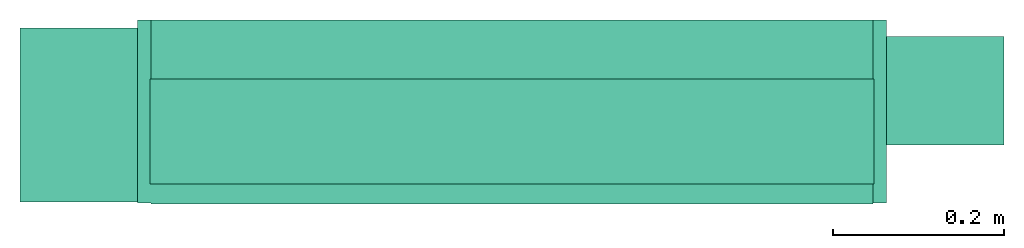
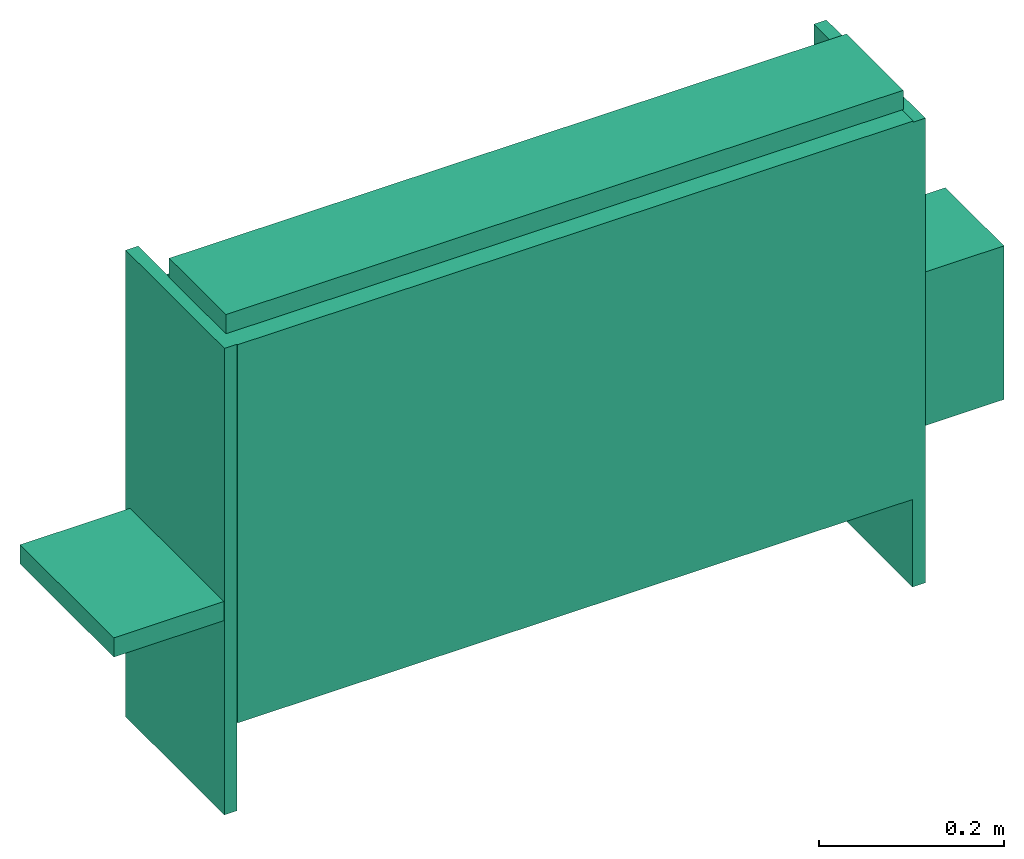
# One storey: 1 energy conversion device.
"""IFC2X3 building model written with IfcOpenShell, lengths in metres."""

from ifc_helpers import new_model, entity, si_unit, converted_unit, origin, origin_with_axes, place, context, subcontext, project, spatial, faceted_brep, type_object, element, save


model = new_model("IFC2X3")

# Units and contexts
model_context = context("Model", 3, precision=1e-05, world=origin())
body_context = subcontext(model_context, "Body", "Model", "MODEL_VIEW")
ifc_project = project(units=[si_unit("LENGTHUNIT", "METRE"), si_unit("AREAUNIT", "SQUARE_METRE"), si_unit("VOLUMEUNIT", "CUBIC_METRE"), converted_unit("PLANEANGLEUNIT", "DEGREE", entity("IfcPlaneAngleMeasure", 0.0174532925199433), si_unit("PLANEANGLEUNIT", "RADIAN"), dimensions=[0, 0, 0, 0, 0, 0, 0]), si_unit("SOLIDANGLEUNIT", "STERADIAN"), si_unit("MASSUNIT", "GRAM"), si_unit("TIMEUNIT", "SECOND"), si_unit("THERMODYNAMICTEMPERATUREUNIT", "DEGREE_CELSIUS"), si_unit("LUMINOUSINTENSITYUNIT", "LUMEN")], contexts=[model_context])

# Site, building, storey
site_placement = place(None, origin_with_axes())
site = spatial("IfcSite", under=ifc_project, at=site_placement, CompositionType="ELEMENT")
building_placement = place(site_placement, origin_with_axes())
building = spatial("IfcBuilding", under=site, at=building_placement, CompositionType="ELEMENT")
storey_placement = place(building_placement, origin_with_axes())
storey = spatial("IfcBuildingStorey", under=building, at=storey_placement, CompositionType="ELEMENT", Elevation=0.0)

# Energy conversion device
heat_exchanger_type = type_object("IfcHeatExchangerType", Name="Vertical Concealed Fan Coil Unit (FCU)", PredefinedType="NOTDEFINED")
energy_conversion_device_placement = place(storey_placement, origin_with_axes())
element("IfcEnergyConversionDevice", 1, at=energy_conversion_device_placement, inside=storey, type_object=heat_exchanger_type, Name="Vertical Concealed Fan Coil Unit (FCU)", context=body_context, shape_type="Brep", body=[
    faceted_brep([(-0.438404005813598, 0.10765326423645, 0.616559604263306), (-0.438404005813598, 0.10765326423645, -0.000609592955932021), (-0.438404005813598, -0.106417922973633, -0.000609592955932021), (-0.438404005813598, -0.106417922973633, 0.616559604263306), (-0.422529005813598, -0.106417922973633, 0.116230405426025), (-0.422529005813598, -0.106417922973633, 0.616559604263306), (-0.422529005813598, -0.106417922973633, -0.000609592955932021), (-0.422529005813598, 0.10765326423645, 0.616559604263306), (-0.422529005813598, 0.0386668773412705, 0.616559604263306), (-0.422529005813598, 0.10765326423645, 0.566699420928955), (-0.422529005813598, 0.10765326423645, 0.116230405426025), (-0.422529005813598, 0.10765326423645, -0.000609592955932021), (0.438404005813598, -0.106417922973633, -0.000609592955932021), (0.422529005813598, -0.106417922973633, 0.116230405426025), (0.422529005813598, -0.106417922973633, -0.000609592955932021), (0.422529005813598, -0.106417922973633, 0.614121187210084), (0.438404005813598, -0.106417922973633, 0.614121187210084), (0.438404005813598, 0.10765326423645, -0.000609592955932021), (0.438404005813598, 0.10765326423645, 0.614121187210084), (0.422529005813598, 0.10765326423645, 0.116230405426025), (0.422529005813598, 0.10765326423645, 0.566699420928955), (0.422529005813598, 0.10765326423645, -0.000609592955932021), (0.422529005813598, 0.10765326423645, 0.614121187210084), (0.422529005813598, 0.0420406388282776, 0.614121187210084), (-0.422529005813598, -0.107637131500244, 0.616559604263306), (0.422529005813598, -0.107637131500244, 0.616559604263306), (0.422529005813598, 0.0386668773412705, 0.616559604263306), (0.422529005813598, -0.107637131500244, 0.116230405426025), (-0.422529005813598, -0.107637131500244, 0.116230405426025)], [[[0, 1, 2]], [[2, 3, 0]], [[3, 2, 4]], [[4, 5, 3]], [[2, 6, 4]], [[7, 8, 9]], [[1, 10, 11]], [[9, 10, 1]], [[1, 0, 9]], [[7, 9, 0]], [[6, 2, 1]], [[1, 11, 6]], [[0, 8, 7]], [[5, 8, 0]], [[0, 3, 5]], [[12, 13, 14]], [[15, 13, 12]], [[12, 16, 15]], [[16, 12, 17]], [[17, 18, 16]], [[18, 17, 19]], [[19, 20, 18]], [[21, 19, 17]], [[18, 20, 22]], [[22, 20, 23]], [[21, 17, 12]], [[12, 14, 21]], [[23, 15, 16]], [[16, 18, 23]], [[22, 23, 18]], [[5, 24, 25]], [[8, 5, 25]], [[25, 26, 8]], [[23, 8, 26]], [[23, 20, 9]], [[9, 8, 23]], [[9, 20, 19]], [[19, 10, 9]], [[4, 13, 27]], [[27, 28, 4]], [[28, 27, 25]], [[25, 24, 28]], [[27, 13, 15]], [[15, 25, 27]], [[26, 25, 15]], [[26, 15, 23]], [[28, 24, 5]], [[5, 4, 28]], [[11, 10, 4]], [[4, 6, 11]], [[19, 21, 14]], [[14, 13, 19]], [[10, 19, 13]], [[13, 4, 10]]]),
    faceted_brep([(0.576167253875733, 0.0885524739742279, 0.152509840679169), (0.576167253875733, -0.0384475229978561, 0.152509840679169), (0.43842304534912, -0.0384475229978561, 0.152509840679169), (0.43842304534912, 0.0885524739742279, 0.152509840679169), (0.576167253875733, -0.0384475229978561, 0.355709828567505), (0.43842304534912, -0.0384475229978561, 0.355709828567505), (0.576167253875733, 0.0885524739742279, 0.355709828567505), (0.43842304534912, 0.0885524739742279, 0.355709828567505)], [[[0, 1, 2]], [[2, 3, 0]], [[1, 4, 5]], [[5, 2, 1]], [[4, 6, 7]], [[7, 5, 4]], [[6, 0, 3]], [[3, 7, 6]], [[6, 4, 1]], [[1, 0, 6]], [[7, 2, 5]], [[2, 7, 3]]]),
    faceted_brep([(-0.576154560852051, 0.0980012734413146, 0.255684635543823), (-0.576154560852051, 0.0980012734413146, 0.281084635543824), (-0.430447466278075, 0.0980012734413146, 0.281084635543824), (-0.430447466278075, 0.0980012734413146, 0.255684635543823), (-0.576154560852051, -0.105198714447022, 0.281084635543824), (-0.430447466278075, -0.105198714447022, 0.281084635543824), (-0.576154560852051, -0.105198714447022, 0.255684635543823), (-0.430447466278075, -0.105198714447022, 0.255684635543823)], [[[0, 1, 2]], [[2, 3, 0]], [[1, 4, 5]], [[5, 2, 1]], [[4, 6, 7]], [[7, 5, 4]], [[6, 0, 3]], [[3, 7, 6]], [[4, 1, 0]], [[0, 6, 4]], [[5, 3, 2]], [[3, 5, 7]]]),
    faceted_brep([(0.423691047286988, -0.0842691235065459, 0.617279037094115), (0.423691047286988, -0.0842691235065459, 0.642679037094115), (-0.423754560852051, -0.0842691235065459, 0.642679037094115), (-0.423754560852051, -0.0842691235065459, 0.617279037094115), (0.423691047286988, 0.0386668773412705, 0.642679037094115), (-0.423754560852051, 0.0386668773412705, 0.642679037094115), (0.423691047286988, 0.0386668773412705, 0.617279037094115), (-0.423754560852051, 0.0386668773412705, 0.617279037094115)], [[[0, 1, 2]], [[2, 3, 0]], [[1, 4, 5]], [[5, 2, 1]], [[4, 6, 7]], [[7, 5, 4]], [[6, 0, 3]], [[3, 7, 6]], [[0, 6, 4]], [[4, 1, 0]], [[3, 5, 7]], [[5, 3, 2]]]),
])

save(model, "model.ifc")
